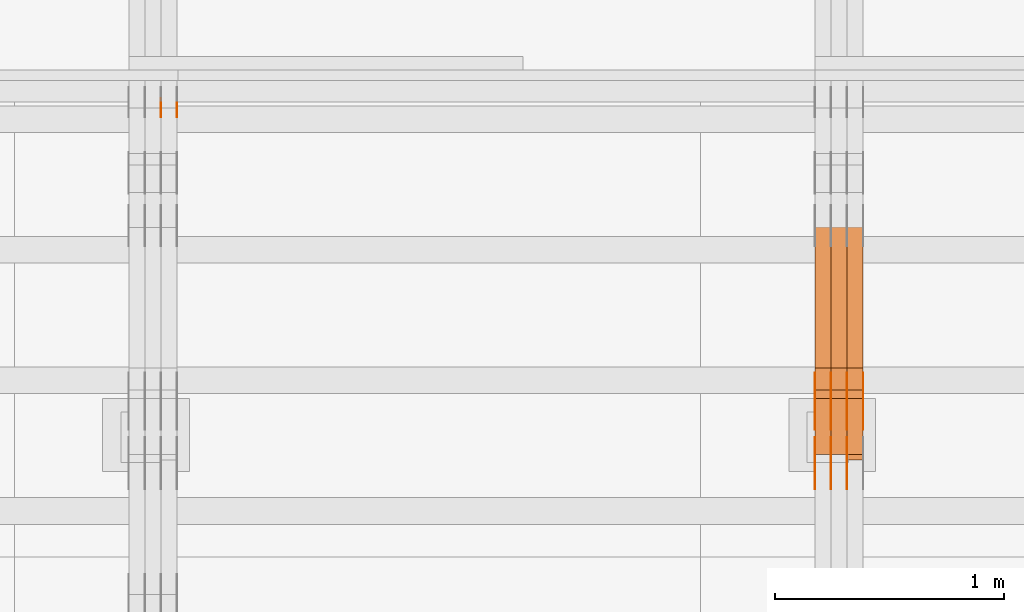
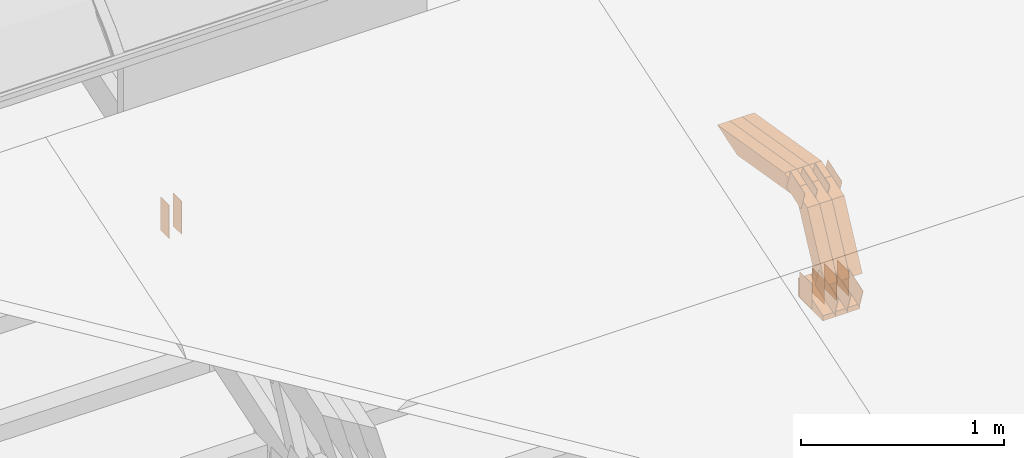
# One storey, part 155 of 385: 29 proxies.
"""IFC2X3 building model written with IfcOpenShell, lengths in millimetres."""

from ifc_helpers import new_model, entity, si_unit, converted_unit, derived_unit, direction, frame, frame_2d, origin, place, context, subcontext, project, spatial, polyline, rectangle, outline, extrude, source, transform, mapped, material, type_object, type_shapes, element, save


model = new_model("IFC2X3")

# Units and contexts
model_context = context("Model", 3, precision=0.01, world=origin(), true_north=direction((6.12303176911189e-17, 1.0)))
body_context = subcontext(model_context, "Body", "Model", "MODEL_VIEW")
ifc_project = project(units=[si_unit("LENGTHUNIT", "METRE", prefix="MILLI"), si_unit("AREAUNIT", "SQUARE_METRE"), si_unit("VOLUMEUNIT", "CUBIC_METRE"), converted_unit("PLANEANGLEUNIT", "DEGREE", entity("IfcRatioMeasure", 0.0174532925199433), si_unit("PLANEANGLEUNIT", "RADIAN"), dimensions=[0, 0, 0, 0, 0, 0, 0]), si_unit("MASSUNIT", "GRAM", prefix="KILO"), derived_unit("MASSDENSITYUNIT", [(si_unit("MASSUNIT", "GRAM", prefix="KILO"), 1), (si_unit("LENGTHUNIT", "METRE"), -3)]), si_unit("TIMEUNIT", "SECOND"), si_unit("FREQUENCYUNIT", "HERTZ"), si_unit("THERMODYNAMICTEMPERATUREUNIT", "DEGREE_CELSIUS"), derived_unit("THERMALTRANSMITTANCEUNIT", [(si_unit("MASSUNIT", "GRAM", prefix="KILO"), 1), (si_unit("THERMODYNAMICTEMPERATUREUNIT", "KELVIN"), -1), (si_unit("TIMEUNIT", "SECOND"), -3)]), derived_unit("VOLUMETRICFLOWRATEUNIT", [(si_unit("LENGTHUNIT", "METRE"), 3), (si_unit("TIMEUNIT", "SECOND"), -1)]), si_unit("ELECTRICCURRENTUNIT", "AMPERE"), si_unit("ELECTRICVOLTAGEUNIT", "VOLT"), si_unit("POWERUNIT", "WATT"), si_unit("FORCEUNIT", "NEWTON", prefix="KILO"), si_unit("ILLUMINANCEUNIT", "LUX"), si_unit("LUMINOUSFLUXUNIT", "LUMEN"), si_unit("LUMINOUSINTENSITYUNIT", "CANDELA"), derived_unit("USERDEFINED", [(si_unit("MASSUNIT", "GRAM", prefix="KILO"), -1), (si_unit("LENGTHUNIT", "METRE"), -2), (si_unit("TIMEUNIT", "SECOND"), 3), (si_unit("LUMINOUSFLUXUNIT", "LUMEN"), 1)]), derived_unit("LINEARVELOCITYUNIT", [(si_unit("LENGTHUNIT", "METRE"), 1), (si_unit("TIMEUNIT", "SECOND"), -1)]), si_unit("PRESSUREUNIT", "PASCAL"), derived_unit("USERDEFINED", [(si_unit("LENGTHUNIT", "METRE"), -2), (si_unit("MASSUNIT", "GRAM", prefix="KILO"), 1), (si_unit("TIMEUNIT", "SECOND"), -2)])], contexts=[model_context])

# Site, building, storey
site_placement = place(None, origin())
site = spatial("IfcSite", under=ifc_project, at=site_placement, CompositionType="ELEMENT")
building_placement = place(site_placement, origin())
building = spatial("IfcBuilding", under=site, at=building_placement, CompositionType="ELEMENT")
storey_placement = place(building_placement, origin())
storey = spatial("IfcBuildingStorey", under=building, at=storey_placement, Name="Default", CompositionType="ELEMENT", Elevation=0.0)

# Proxies
ifc_material_1 = material(Name="IfcSurfaceStyle #344759")
building_element_proxy_type_1 = type_object("IfcBuildingElementProxyType", PredefinedType="NOTDEFINED", material=ifc_material_1)
shared_shape_1 = source(origin(), body_context, "Body", "SweptSolid", [
    extrude(outline(polyline([(-99.9997874178038, -60.0000528641967), (99.9998102700997, -60.0000528641967), (99.9998251396068, 60.0000528641967), (-99.9998479919027, 60.0000528641967), (-99.9997874178038, -60.0000528641967)])), frame((99.9999918898597, 60.0000528641967, 0.0), z_axis=(0.0, 0.0, 1.0), x_axis=(-1.0, 0.0, 0.0)), (0.0, 0.0, 1.0), 1.3),
])
type_shapes(building_element_proxy_type_1, [shared_shape_1])
proxy_1_placement = place(building_placement, frame((27315.0, 11991.9568177725, 3072.52282247925), z_axis=(-1.0, 0.0, 0.0), x_axis=(0.0, 0.951056516295124, 0.309016994375039)))
element("IfcBuildingElementProxy", 1, at=proxy_1_placement, inside=storey, type_object=building_element_proxy_type_1, material=ifc_material_1, context=body_context, shape_type="MappedRepresentation", body=[
    mapped(shared_shape_1, transform((0.0, 0.0, 0.0), scale=1.0)),
])
ifc_material_2 = material(Name="IfcSurfaceStyle #344702")
building_element_proxy_type_2 = type_object("IfcBuildingElementProxyType", PredefinedType="NOTDEFINED", material=ifc_material_2)
shared_shape_2 = source(origin(), body_context, "Body", "SweptSolid", [
    extrude(outline(polyline([(-99.9997874178038, -60.0000528641967), (99.9998102700997, -60.0000528641967), (99.9998251396068, 60.0000528641967), (-99.9998479919027, 60.0000528641967), (-99.9997874178038, -60.0000528641967)])), frame((99.9999918898597, 60.0000528641967, 0.0), z_axis=(0.0, 0.0, 1.0), x_axis=(-1.0, 0.0, 0.0)), (0.0, 0.0, 1.0), 1.3),
])
type_shapes(building_element_proxy_type_2, [shared_shape_2])
proxy_2_placement = place(building_placement, frame((27316.3, 11991.9568177725, 3072.52282247925), z_axis=(-1.0, 0.0, 0.0), x_axis=(0.0, 0.951056516295124, 0.309016994375039)))
element("IfcBuildingElementProxy", 2, at=proxy_2_placement, inside=storey, type_object=building_element_proxy_type_2, material=ifc_material_2, context=body_context, shape_type="MappedRepresentation", body=[
    mapped(shared_shape_2, transform((0.0, 0.0, 0.0), scale=1.0)),
])
ifc_material_3 = material(Name="IfcSurfaceStyle #344645")
building_element_proxy_type_3 = type_object("IfcBuildingElementProxyType", PredefinedType="NOTDEFINED", material=ifc_material_3)
shared_shape_3 = source(origin(), body_context, "Body", "SweptSolid", [
    extrude(outline(polyline([(-99.9997874178038, -60.0000528641967), (99.9998102700997, -60.0000528641967), (99.9998251396068, 60.0000528641967), (-99.9998479919027, 60.0000528641967), (-99.9997874178038, -60.0000528641967)])), frame((99.9999918898597, 60.0000528641967, 0.0), z_axis=(0.0, 0.0, 1.0), x_axis=(-1.0, 0.0, 0.0)), (0.0, 0.0, 1.0), 1.29999999999998),
])
type_shapes(building_element_proxy_type_3, [shared_shape_3])
proxy_3_placement = place(building_placement, frame((27245.0, 11991.9568177725, 3072.52282247925), z_axis=(-1.0, 0.0, 0.0), x_axis=(0.0, 0.951056516295124, 0.309016994375039)))
element("IfcBuildingElementProxy", 3, at=proxy_3_placement, inside=storey, type_object=building_element_proxy_type_3, material=ifc_material_3, context=body_context, shape_type="MappedRepresentation", body=[
    mapped(shared_shape_3, transform((0.0, 0.0, 0.0), scale=1.0)),
])
ifc_material_4 = material(Name="IfcSurfaceStyle #344588")
building_element_proxy_type_4 = type_object("IfcBuildingElementProxyType", PredefinedType="NOTDEFINED", material=ifc_material_4)
shared_shape_4 = source(origin(), body_context, "Body", "SweptSolid", [
    extrude(outline(polyline([(-99.9997874178038, -60.0000528641967), (99.9998102700997, -60.0000528641967), (99.9998251396068, 60.0000528641967), (-99.9998479919027, 60.0000528641967), (-99.9997874178038, -60.0000528641967)])), frame((99.9999918898597, 60.0000528641967, 0.0), z_axis=(0.0, 0.0, 1.0), x_axis=(-1.0, 0.0, 0.0)), (0.0, 0.0, 1.0), 1.29999999999998),
])
type_shapes(building_element_proxy_type_4, [shared_shape_4])
proxy_4_placement = place(building_placement, frame((27246.3, 11991.9568177725, 3072.52282247925), z_axis=(-1.0, 0.0, 0.0), x_axis=(0.0, 0.951056516295124, 0.309016994375039)))
element("IfcBuildingElementProxy", 4, at=proxy_4_placement, inside=storey, type_object=building_element_proxy_type_4, material=ifc_material_4, context=body_context, shape_type="MappedRepresentation", body=[
    mapped(shared_shape_4, transform((0.0, 0.0, 0.0), scale=1.0)),
])
ifc_material_5 = material(Name="IfcSurfaceStyle #344531")
building_element_proxy_type_5 = type_object("IfcBuildingElementProxyType", PredefinedType="NOTDEFINED", material=ifc_material_5)
shared_shape_5 = source(origin(), body_context, "Body", "SweptSolid", [
    extrude(outline(polyline([(-99.9997874178038, -60.0000528641967), (99.9998102700997, -60.0000528641967), (99.9998251396068, 60.0000528641967), (-99.9998479919027, 60.0000528641967), (-99.9997874178038, -60.0000528641967)])), frame((99.9999918898597, 60.0000528641967, 0.0), z_axis=(0.0, 0.0, 1.0), x_axis=(-1.0, 0.0, 0.0)), (0.0, 0.0, 1.0), 1.29999999999999),
])
type_shapes(building_element_proxy_type_5, [shared_shape_5])
proxy_5_placement = place(building_placement, frame((27175.0, 11991.9568177725, 3072.52282247925), z_axis=(-1.0, 0.0, 0.0), x_axis=(0.0, 0.951056516295124, 0.309016994375039)))
element("IfcBuildingElementProxy", 5, at=proxy_5_placement, inside=storey, type_object=building_element_proxy_type_5, material=ifc_material_5, context=body_context, shape_type="MappedRepresentation", body=[
    mapped(shared_shape_5, transform((0.0, 0.0, 0.0), scale=1.0)),
])
ifc_material_6 = material(Name="IfcSurfaceStyle #344474")
building_element_proxy_type_6 = type_object("IfcBuildingElementProxyType", PredefinedType="NOTDEFINED", material=ifc_material_6)
shared_shape_6 = source(origin(), body_context, "Body", "SweptSolid", [
    extrude(rectangle(XDim=150.0, YDim=119.999999999985, at=frame_2d((-7.105427357601e-15, 0.0), x_axis=(1.0, 0.0))), frame((75.0, 60.0, 0.0), z_axis=(0.0, 0.0, 1.0), x_axis=(-1.0, 0.0, 0.0)), (0.0, 0.0, 1.0), 1.3),
])
type_shapes(building_element_proxy_type_6, [shared_shape_6])
proxy_6_placement = place(building_placement, frame((27386.3, 12372.95703125, 3007.04687500001), z_axis=(-1.0, 0.0, 0.0), x_axis=(0.0, 0.0, -1.0)))
element("IfcBuildingElementProxy", 6, at=proxy_6_placement, inside=storey, type_object=building_element_proxy_type_6, material=ifc_material_6, context=body_context, shape_type="MappedRepresentation", body=[
    mapped(shared_shape_6, transform((0.0, 0.0, 0.0), scale=1.0)),
])
ifc_material_7 = material(Name="IfcSurfaceStyle #344417")
building_element_proxy_type_7 = type_object("IfcBuildingElementProxyType", PredefinedType="NOTDEFINED", material=ifc_material_7)
shared_shape_7 = source(origin(), body_context, "Body", "SweptSolid", [
    extrude(rectangle(XDim=150.0, YDim=119.999999999985, at=frame_2d((-7.105427357601e-15, 0.0), x_axis=(1.0, 0.0))), frame((75.0, 60.0, 0.0), z_axis=(0.0, 0.0, 1.0), x_axis=(-1.0, 0.0, 0.0)), (0.0, 0.0, 1.0), 1.3),
])
type_shapes(building_element_proxy_type_7, [shared_shape_7])
proxy_7_placement = place(building_placement, frame((27315.0, 12372.95703125, 3007.04687500001), z_axis=(-1.0, 0.0, 0.0), x_axis=(0.0, 0.0, -1.0)))
element("IfcBuildingElementProxy", 7, at=proxy_7_placement, inside=storey, type_object=building_element_proxy_type_7, material=ifc_material_7, context=body_context, shape_type="MappedRepresentation", body=[
    mapped(shared_shape_7, transform((0.0, 0.0, 0.0), scale=1.0)),
])
ifc_material_8 = material(Name="IfcSurfaceStyle #344360")
building_element_proxy_type_8 = type_object("IfcBuildingElementProxyType", PredefinedType="NOTDEFINED", material=ifc_material_8)
shared_shape_8 = source(origin(), body_context, "Body", "SweptSolid", [
    extrude(rectangle(XDim=150.0, YDim=119.999999999985, at=frame_2d((-7.105427357601e-15, 0.0), x_axis=(1.0, 0.0))), frame((75.0, 60.0, 0.0), z_axis=(0.0, 0.0, 1.0), x_axis=(-1.0, 0.0, 0.0)), (0.0, 0.0, 1.0), 1.3),
])
type_shapes(building_element_proxy_type_8, [shared_shape_8])
proxy_8_placement = place(building_placement, frame((27316.3, 12372.95703125, 3007.04687500001), z_axis=(-1.0, 0.0, 0.0), x_axis=(0.0, 0.0, -1.0)))
element("IfcBuildingElementProxy", 8, at=proxy_8_placement, inside=storey, type_object=building_element_proxy_type_8, material=ifc_material_8, context=body_context, shape_type="MappedRepresentation", body=[
    mapped(shared_shape_8, transform((0.0, 0.0, 0.0), scale=1.0)),
])
ifc_material_9 = material(Name="IfcSurfaceStyle #344303")
building_element_proxy_type_9 = type_object("IfcBuildingElementProxyType", PredefinedType="NOTDEFINED", material=ifc_material_9)
shared_shape_9 = source(origin(), body_context, "Body", "SweptSolid", [
    extrude(rectangle(XDim=150.0, YDim=119.999999999985, at=frame_2d((-7.105427357601e-15, 0.0), x_axis=(1.0, 0.0))), frame((75.0, 60.0, 0.0), z_axis=(0.0, 0.0, 1.0), x_axis=(-1.0, 0.0, 0.0)), (0.0, 0.0, 1.0), 1.29999999999999),
])
type_shapes(building_element_proxy_type_9, [shared_shape_9])
proxy_9_placement = place(building_placement, frame((27245.0, 12372.95703125, 3007.04687500001), z_axis=(-1.0, 0.0, 0.0), x_axis=(0.0, 0.0, -1.0)))
element("IfcBuildingElementProxy", 9, at=proxy_9_placement, inside=storey, type_object=building_element_proxy_type_9, material=ifc_material_9, context=body_context, shape_type="MappedRepresentation", body=[
    mapped(shared_shape_9, transform((0.0, 0.0, 0.0), scale=1.0)),
])
ifc_material_10 = material(Name="IfcSurfaceStyle #344246")
building_element_proxy_type_10 = type_object("IfcBuildingElementProxyType", PredefinedType="NOTDEFINED", material=ifc_material_10)
shared_shape_10 = source(origin(), body_context, "Body", "SweptSolid", [
    extrude(rectangle(XDim=150.0, YDim=119.999999999985, at=frame_2d((-7.105427357601e-15, 0.0), x_axis=(1.0, 0.0))), frame((75.0, 60.0, 0.0), z_axis=(0.0, 0.0, 1.0), x_axis=(-1.0, 0.0, 0.0)), (0.0, 0.0, 1.0), 1.29999999999999),
])
type_shapes(building_element_proxy_type_10, [shared_shape_10])
proxy_10_placement = place(building_placement, frame((27246.3, 12372.95703125, 3007.04687500001), z_axis=(-1.0, 0.0, 0.0), x_axis=(0.0, 0.0, -1.0)))
element("IfcBuildingElementProxy", 10, at=proxy_10_placement, inside=storey, type_object=building_element_proxy_type_10, material=ifc_material_10, context=body_context, shape_type="MappedRepresentation", body=[
    mapped(shared_shape_10, transform((0.0, 0.0, 0.0), scale=1.0)),
])
ifc_material_11 = material(Name="IfcSurfaceStyle #344189")
building_element_proxy_type_11 = type_object("IfcBuildingElementProxyType", PredefinedType="NOTDEFINED", material=ifc_material_11)
shared_shape_11 = source(origin(), body_context, "Body", "SweptSolid", [
    extrude(rectangle(XDim=150.0, YDim=119.999999999985, at=frame_2d((-7.105427357601e-15, 0.0), x_axis=(1.0, 0.0))), frame((75.0, 60.0, 0.0), z_axis=(0.0, 0.0, 1.0), x_axis=(-1.0, 0.0, 0.0)), (0.0, 0.0, 1.0), 1.29999999999999),
])
type_shapes(building_element_proxy_type_11, [shared_shape_11])
proxy_11_placement = place(building_placement, frame((27175.0, 12372.95703125, 3007.04687500001), z_axis=(-1.0, 0.0, 0.0), x_axis=(0.0, 0.0, -1.0)))
element("IfcBuildingElementProxy", 11, at=proxy_11_placement, inside=storey, type_object=building_element_proxy_type_11, material=ifc_material_11, context=body_context, shape_type="MappedRepresentation", body=[
    mapped(shared_shape_11, transform((0.0, 0.0, 0.0), scale=1.0)),
])
ifc_material_12 = material(Name="IfcSurfaceStyle #337292")
building_element_proxy_type_12 = type_object("IfcBuildingElementProxyType", PredefinedType="NOTDEFINED", material=ifc_material_12)
shared_shape_12 = source(origin(), body_context, "Body", "SweptSolid", [
    extrude(outline(polyline([(-74.9998754286244, -60.0000016373506), (74.9998605591063, -60.0000016373506), (74.9998754286244, 60.0000016373506), (-74.9998605591063, 60.0000016373506), (-74.9998754286244, -60.0000016373506)])), frame((74.9998754286244, 60.0000016373506, 0.0), z_axis=(0.0, 0.0, 1.0), x_axis=(-1.0, 0.0, 0.0)), (0.0, 0.0, 1.0), 1.3),
])
type_shapes(building_element_proxy_type_12, [shared_shape_12])
proxy_12_placement = place(building_placement, frame((27386.3, 12321.1620861463, 3506.17707344366), z_axis=(-1.0, 0.0, 0.0), x_axis=(0.0, 0.951056516295154, 0.309016994374948)))
element("IfcBuildingElementProxy", 12, at=proxy_12_placement, inside=storey, type_object=building_element_proxy_type_12, material=ifc_material_12, context=body_context, shape_type="MappedRepresentation", body=[
    mapped(shared_shape_12, transform((0.0, 0.0, 0.0), scale=1.0)),
])
ifc_material_13 = material(Name="IfcSurfaceStyle #337235")
building_element_proxy_type_13 = type_object("IfcBuildingElementProxyType", PredefinedType="NOTDEFINED", material=ifc_material_13)
shared_shape_13 = source(origin(), body_context, "Body", "SweptSolid", [
    extrude(outline(polyline([(-74.9998754286244, -60.0000016373506), (74.9998605591063, -60.0000016373506), (74.9998754286244, 60.0000016373506), (-74.9998605591063, 60.0000016373506), (-74.9998754286244, -60.0000016373506)])), frame((74.9998754286244, 60.0000016373506, 0.0), z_axis=(0.0, 0.0, 1.0), x_axis=(-1.0, 0.0, 0.0)), (0.0, 0.0, 1.0), 1.3),
])
type_shapes(building_element_proxy_type_13, [shared_shape_13])
proxy_13_placement = place(building_placement, frame((27315.0, 12321.1620861463, 3506.17707344366), z_axis=(-1.0, 0.0, 0.0), x_axis=(0.0, 0.951056516295154, 0.309016994374948)))
element("IfcBuildingElementProxy", 13, at=proxy_13_placement, inside=storey, type_object=building_element_proxy_type_13, material=ifc_material_13, context=body_context, shape_type="MappedRepresentation", body=[
    mapped(shared_shape_13, transform((0.0, 0.0, 0.0), scale=1.0)),
])
ifc_material_14 = material(Name="IfcSurfaceStyle #337178")
building_element_proxy_type_14 = type_object("IfcBuildingElementProxyType", PredefinedType="NOTDEFINED", material=ifc_material_14)
shared_shape_14 = source(origin(), body_context, "Body", "SweptSolid", [
    extrude(outline(polyline([(-74.9998754286244, -60.0000016373506), (74.9998605591063, -60.0000016373506), (74.9998754286244, 60.0000016373506), (-74.9998605591063, 60.0000016373506), (-74.9998754286244, -60.0000016373506)])), frame((74.9998754286244, 60.0000016373506, 0.0), z_axis=(0.0, 0.0, 1.0), x_axis=(-1.0, 0.0, 0.0)), (0.0, 0.0, 1.0), 1.3),
])
type_shapes(building_element_proxy_type_14, [shared_shape_14])
proxy_14_placement = place(building_placement, frame((27316.3, 12321.1620861463, 3506.17707344366), z_axis=(-1.0, 0.0, 0.0), x_axis=(0.0, 0.951056516295154, 0.309016994374948)))
element("IfcBuildingElementProxy", 14, at=proxy_14_placement, inside=storey, type_object=building_element_proxy_type_14, material=ifc_material_14, context=body_context, shape_type="MappedRepresentation", body=[
    mapped(shared_shape_14, transform((0.0, 0.0, 0.0), scale=1.0)),
])
ifc_material_15 = material(Name="IfcSurfaceStyle #337121")
building_element_proxy_type_15 = type_object("IfcBuildingElementProxyType", PredefinedType="NOTDEFINED", material=ifc_material_15)
shared_shape_15 = source(origin(), body_context, "Body", "SweptSolid", [
    extrude(outline(polyline([(-74.9998754286244, -60.0000016373506), (74.9998605591063, -60.0000016373506), (74.9998754286244, 60.0000016373506), (-74.9998605591063, 60.0000016373506), (-74.9998754286244, -60.0000016373506)])), frame((74.9998754286244, 60.0000016373506, 0.0), z_axis=(0.0, 0.0, 1.0), x_axis=(-1.0, 0.0, 0.0)), (0.0, 0.0, 1.0), 1.29999999999999),
])
type_shapes(building_element_proxy_type_15, [shared_shape_15])
proxy_15_placement = place(building_placement, frame((27245.0, 12321.1620861463, 3506.17707344366), z_axis=(-1.0, 0.0, 0.0), x_axis=(0.0, 0.951056516295154, 0.309016994374948)))
element("IfcBuildingElementProxy", 15, at=proxy_15_placement, inside=storey, type_object=building_element_proxy_type_15, material=ifc_material_15, context=body_context, shape_type="MappedRepresentation", body=[
    mapped(shared_shape_15, transform((0.0, 0.0, 0.0), scale=1.0)),
])
ifc_material_16 = material(Name="IfcSurfaceStyle #337064")
building_element_proxy_type_16 = type_object("IfcBuildingElementProxyType", PredefinedType="NOTDEFINED", material=ifc_material_16)
shared_shape_16 = source(origin(), body_context, "Body", "SweptSolid", [
    extrude(outline(polyline([(-74.9998754286244, -60.0000016373506), (74.9998605591063, -60.0000016373506), (74.9998754286244, 60.0000016373506), (-74.9998605591063, 60.0000016373506), (-74.9998754286244, -60.0000016373506)])), frame((74.9998754286244, 60.0000016373506, 0.0), z_axis=(0.0, 0.0, 1.0), x_axis=(-1.0, 0.0, 0.0)), (0.0, 0.0, 1.0), 1.29999999999999),
])
type_shapes(building_element_proxy_type_16, [shared_shape_16])
proxy_16_placement = place(building_placement, frame((27246.3, 12321.1620861463, 3506.17707344366), z_axis=(-1.0, 0.0, 0.0), x_axis=(0.0, 0.951056516295154, 0.309016994374948)))
element("IfcBuildingElementProxy", 16, at=proxy_16_placement, inside=storey, type_object=building_element_proxy_type_16, material=ifc_material_16, context=body_context, shape_type="MappedRepresentation", body=[
    mapped(shared_shape_16, transform((0.0, 0.0, 0.0), scale=1.0)),
])
ifc_material_17 = material(Name="IfcSurfaceStyle #337007")
building_element_proxy_type_17 = type_object("IfcBuildingElementProxyType", PredefinedType="NOTDEFINED", material=ifc_material_17)
shared_shape_17 = source(origin(), body_context, "Body", "SweptSolid", [
    extrude(outline(polyline([(-74.9998754286244, -60.0000016373506), (74.9998605591063, -60.0000016373506), (74.9998754286244, 60.0000016373506), (-74.9998605591063, 60.0000016373506), (-74.9998754286244, -60.0000016373506)])), frame((74.9998754286244, 60.0000016373506, 0.0), z_axis=(0.0, 0.0, 1.0), x_axis=(-1.0, 0.0, 0.0)), (0.0, 0.0, 1.0), 1.29999999999999),
])
type_shapes(building_element_proxy_type_17, [shared_shape_17])
proxy_17_placement = place(building_placement, frame((27175.0, 12321.1620861463, 3506.17707344366), z_axis=(-1.0, 0.0, 0.0), x_axis=(0.0, 0.951056516295154, 0.309016994374948)))
element("IfcBuildingElementProxy", 17, at=proxy_17_placement, inside=storey, type_object=building_element_proxy_type_17, material=ifc_material_17, context=body_context, shape_type="MappedRepresentation", body=[
    mapped(shared_shape_17, transform((0.0, 0.0, 0.0), scale=1.0)),
])
ifc_material_18 = material(Name="IfcSurfaceStyle #328832")
building_element_proxy_type_18 = type_object("IfcBuildingElementProxyType", Name="T1-E1 328830", PredefinedType="NOTDEFINED", material=ifc_material_18)
shared_shape_18 = source(origin(), body_context, "Body", "SweptSolid", [
    extrude(outline(polyline([(-75.1378173828004, -122.500000000005), (35.3350830078246, -122.500000000005), (35.3350830078004, 122.500000000005), (4.46765136717545, 122.500000000005), (-75.1378173828004, -122.500000000005)])), frame((35.3350830078246, 122.500000104877, 0.0), z_axis=(0.0, 0.0, 1.0), x_axis=(-1.0, 0.0, 0.0)), (0.0, 0.0, 1.0), 70.0),
])
type_shapes(building_element_proxy_type_18, [shared_shape_18])
proxy_18_placement = place(building_placement, frame((27385.0, 12145.0, 2849.54565429685), z_axis=(-1.0, 0.0, 0.0), x_axis=(0.0, 0.0, 1.0)))
element("IfcBuildingElementProxy", 18, at=proxy_18_placement, inside=storey, type_object=building_element_proxy_type_18, material=ifc_material_18, Name="T1-E1", context=body_context, shape_type="MappedRepresentation", body=[
    mapped(shared_shape_18, transform((0.0, 0.0, 0.0), scale=1.0)),
])
ifc_material_19 = material(Name="IfcSurfaceStyle #328775")
building_element_proxy_type_19 = type_object("IfcBuildingElementProxyType", Name="T1-E1 328773", PredefinedType="NOTDEFINED", material=ifc_material_19)
shared_shape_19 = source(origin(), body_context, "Body", "SweptSolid", [
    extrude(outline(polyline([(-75.1378173828004, -122.500000000005), (35.3350830078246, -122.500000000005), (35.3350830078004, 122.500000000005), (4.46765136717545, 122.500000000005), (-75.1378173828004, -122.500000000005)])), frame((35.3350830078246, 122.500000104877, 0.0), z_axis=(0.0, 0.0, 1.0), x_axis=(-1.0, 0.0, 0.0)), (0.0, 0.0, 1.0), 70.0),
])
type_shapes(building_element_proxy_type_19, [shared_shape_19])
proxy_19_placement = place(building_placement, frame((27315.0, 12145.0, 2849.54565429685), z_axis=(-1.0, 0.0, 0.0), x_axis=(0.0, 0.0, 1.0)))
element("IfcBuildingElementProxy", 19, at=proxy_19_placement, inside=storey, type_object=building_element_proxy_type_19, material=ifc_material_19, Name="T1-E1", context=body_context, shape_type="MappedRepresentation", body=[
    mapped(shared_shape_19, transform((0.0, 0.0, 0.0), scale=1.0)),
])
ifc_material_20 = material(Name="IfcSurfaceStyle #328718")
building_element_proxy_type_20 = type_object("IfcBuildingElementProxyType", Name="T1-E1 328716", PredefinedType="NOTDEFINED", material=ifc_material_20)
shared_shape_20 = source(origin(), body_context, "Body", "SweptSolid", [
    extrude(outline(polyline([(-75.1378173828004, -122.500000000005), (35.3350830078246, -122.500000000005), (35.3350830078004, 122.500000000005), (4.46765136717545, 122.500000000005), (-75.1378173828004, -122.500000000005)])), frame((35.3350830078246, 122.500000104877, 0.0), z_axis=(0.0, 0.0, 1.0), x_axis=(-1.0, 0.0, 0.0)), (0.0, 0.0, 1.0), 70.0),
])
type_shapes(building_element_proxy_type_20, [shared_shape_20])
proxy_20_placement = place(building_placement, frame((27245.0, 12145.0, 2849.54565429685), z_axis=(-1.0, 0.0, 0.0), x_axis=(0.0, 0.0, 1.0)))
element("IfcBuildingElementProxy", 20, at=proxy_20_placement, inside=storey, type_object=building_element_proxy_type_20, material=ifc_material_20, Name="T1-E1", context=body_context, shape_type="MappedRepresentation", body=[
    mapped(shared_shape_20, transform((0.0, 0.0, 0.0), scale=1.0)),
])
ifc_material_21 = material(Name="IfcSurfaceStyle #327104")
building_element_proxy_type_21 = type_object("IfcBuildingElementProxyType", Name="T1-W7 327102", PredefinedType="NOTDEFINED", material=ifc_material_21)
shared_shape_21 = source(origin(), body_context, "Body", "SweptSolid", [
    extrude(outline(polyline([(-296.174043820986, -47.5000676566704), (297.841254477443, -47.5000676566704), (283.518570346415, -7.10254316533821e-06), (192.674144473719, 47.500071207942), (-477.859925476591, 47.500071207942), (-296.174043820986, -47.5000676566704)])), frame((297.841254477443, 47.5000816097442, 0.0), z_axis=(0.0, 0.0, 1.0), x_axis=(-1.0, 0.0, 0.0)), (0.0, 0.0, 1.0), 70.0),
])
type_shapes(building_element_proxy_type_21, [shared_shape_21])
proxy_21_placement = place(building_placement, frame((27385.0, 12419.2991208897, 3526.2136755972), z_axis=(-1.0, 0.0, 0.0), x_axis=(0.0, 0.985983815111804, -0.166840991178939)))
element("IfcBuildingElementProxy", 21, at=proxy_21_placement, inside=storey, type_object=building_element_proxy_type_21, material=ifc_material_21, Name="T1-W7", context=body_context, shape_type="MappedRepresentation", body=[
    mapped(shared_shape_21, transform((0.0, 0.0, 0.0), scale=1.0)),
])
ifc_material_22 = material(Name="IfcSurfaceStyle #327038")
building_element_proxy_type_22 = type_object("IfcBuildingElementProxyType", Name="T1-W7 327036", PredefinedType="NOTDEFINED", material=ifc_material_22)
shared_shape_22 = source(origin(), body_context, "Body", "SweptSolid", [
    extrude(outline(polyline([(-296.174043820986, -47.5000676566704), (297.841254477443, -47.5000676566704), (283.518570346415, -7.10254316533821e-06), (192.674144473719, 47.500071207942), (-477.859925476591, 47.500071207942), (-296.174043820986, -47.5000676566704)])), frame((297.841254477443, 47.5000816097442, 0.0), z_axis=(0.0, 0.0, 1.0), x_axis=(-1.0, 0.0, 0.0)), (0.0, 0.0, 1.0), 70.0),
])
type_shapes(building_element_proxy_type_22, [shared_shape_22])
proxy_22_placement = place(building_placement, frame((27315.0, 12419.2991208897, 3526.2136755972), z_axis=(-1.0, 0.0, 0.0), x_axis=(0.0, 0.985983815111804, -0.166840991178939)))
element("IfcBuildingElementProxy", 22, at=proxy_22_placement, inside=storey, type_object=building_element_proxy_type_22, material=ifc_material_22, Name="T1-W7", context=body_context, shape_type="MappedRepresentation", body=[
    mapped(shared_shape_22, transform((0.0, 0.0, 0.0), scale=1.0)),
])
ifc_material_23 = material(Name="IfcSurfaceStyle #326972")
building_element_proxy_type_23 = type_object("IfcBuildingElementProxyType", Name="T1-W7 326970", PredefinedType="NOTDEFINED", material=ifc_material_23)
shared_shape_23 = source(origin(), body_context, "Body", "SweptSolid", [
    extrude(outline(polyline([(-296.174043820986, -47.5000676566704), (297.841254477443, -47.5000676566704), (283.518570346415, -7.10254316533821e-06), (192.674144473719, 47.500071207942), (-477.859925476591, 47.500071207942), (-296.174043820986, -47.5000676566704)])), frame((297.841254477443, 47.5000816097442, 0.0), z_axis=(0.0, 0.0, 1.0), x_axis=(-1.0, 0.0, 0.0)), (0.0, 0.0, 1.0), 70.0),
])
type_shapes(building_element_proxy_type_23, [shared_shape_23])
proxy_23_placement = place(building_placement, frame((27245.0, 12419.2991208897, 3526.2136755972), z_axis=(-1.0, 0.0, 0.0), x_axis=(0.0, 0.985983815111804, -0.166840991178939)))
element("IfcBuildingElementProxy", 23, at=proxy_23_placement, inside=storey, type_object=building_element_proxy_type_23, material=ifc_material_23, Name="T1-W7", context=body_context, shape_type="MappedRepresentation", body=[
    mapped(shared_shape_23, transform((0.0, 0.0, 0.0), scale=1.0)),
])
ifc_material_24 = material(Name="IfcSurfaceStyle #326708")
building_element_proxy_type_24 = type_object("IfcBuildingElementProxyType", Name="T1-W36 326706", PredefinedType="NOTDEFINED", material=ifc_material_24)
shared_shape_24 = source(origin(), body_context, "Body", "SweptSolid", [
    extrude(outline(polyline([(-300.714670922549, -47.4998881108849), (134.031527004269, -47.499888110885), (180.52054953879, -0.000136170977331764), (193.89900152221, 47.500563476126), (-207.736407142719, 47.4993489166213), (-300.714670922549, -47.4998881108849)])), frame((193.899145164686, 47.5001861375837, 0.0), z_axis=(0.0, 0.0, 1.0), x_axis=(-1.0, 3.02403492980632e-06, 0.0)), (0.0, 0.0, 1.0), 70.0),
])
type_shapes(building_element_proxy_type_24, [shared_shape_24])
proxy_24_placement = place(building_placement, frame((27385.0, 12120.5935627532, 3076.1128858536), z_axis=(-1.0, 0.0, 0.0), x_axis=(0.0, 0.444384650266842, 0.895836080210669)))
element("IfcBuildingElementProxy", 24, at=proxy_24_placement, inside=storey, type_object=building_element_proxy_type_24, material=ifc_material_24, Name="T1-W36", context=body_context, shape_type="MappedRepresentation", body=[
    mapped(shared_shape_24, transform((0.0, 0.0, 0.0), scale=1.0)),
])
ifc_material_25 = material(Name="IfcSurfaceStyle #326642")
building_element_proxy_type_25 = type_object("IfcBuildingElementProxyType", Name="T1-W36 326640", PredefinedType="NOTDEFINED", material=ifc_material_25)
shared_shape_25 = source(origin(), body_context, "Body", "SweptSolid", [
    extrude(outline(polyline([(-300.714670922549, -47.4998881108849), (134.031527004269, -47.499888110885), (180.52054953879, -0.000136170977331764), (193.89900152221, 47.500563476126), (-207.736407142719, 47.4993489166213), (-300.714670922549, -47.4998881108849)])), frame((193.899145164686, 47.5001861375837, 0.0), z_axis=(0.0, 0.0, 1.0), x_axis=(-1.0, 3.02403492980632e-06, 0.0)), (0.0, 0.0, 1.0), 70.0),
])
type_shapes(building_element_proxy_type_25, [shared_shape_25])
proxy_25_placement = place(building_placement, frame((27315.0, 12120.5935627532, 3076.1128858536), z_axis=(-1.0, 0.0, 0.0), x_axis=(0.0, 0.444384650266842, 0.895836080210669)))
element("IfcBuildingElementProxy", 25, at=proxy_25_placement, inside=storey, type_object=building_element_proxy_type_25, material=ifc_material_25, Name="T1-W36", context=body_context, shape_type="MappedRepresentation", body=[
    mapped(shared_shape_25, transform((0.0, 0.0, 0.0), scale=1.0)),
])
ifc_material_26 = material(Name="IfcSurfaceStyle #326576")
building_element_proxy_type_26 = type_object("IfcBuildingElementProxyType", Name="T1-W36 326574", PredefinedType="NOTDEFINED", material=ifc_material_26)
shared_shape_26 = source(origin(), body_context, "Body", "SweptSolid", [
    extrude(outline(polyline([(-300.714670922549, -47.4998881108849), (134.031527004269, -47.499888110885), (180.52054953879, -0.000136170977331764), (193.89900152221, 47.500563476126), (-207.736407142719, 47.4993489166213), (-300.714670922549, -47.4998881108849)])), frame((193.899145164686, 47.5001861375837, 0.0), z_axis=(0.0, 0.0, 1.0), x_axis=(-1.0, 3.02403492980632e-06, 0.0)), (0.0, 0.0, 1.0), 70.0),
])
type_shapes(building_element_proxy_type_26, [shared_shape_26])
proxy_26_placement = place(building_placement, frame((27245.0, 12120.5935627532, 3076.1128858536), z_axis=(-1.0, 0.0, 0.0), x_axis=(0.0, 0.444384650266842, 0.895836080210669)))
element("IfcBuildingElementProxy", 26, at=proxy_26_placement, inside=storey, type_object=building_element_proxy_type_26, material=ifc_material_26, Name="T1-W36", context=body_context, shape_type="MappedRepresentation", body=[
    mapped(shared_shape_26, transform((0.0, 0.0, 0.0), scale=1.0)),
])
ifc_material_27 = material(Name="IfcSurfaceStyle #312436")
building_element_proxy_type_27 = type_object("IfcBuildingElementProxyType", PredefinedType="NOTDEFINED", material=ifc_material_27)
shared_shape_27 = source(origin(), body_context, "Body", "SweptSolid", [
    extrude(rectangle(XDim=200.0, YDim=84.0, at=frame_2d((0.0, -7.105427357601e-15), x_axis=(1.0, 0.0))), frame((100.0, 42.0, 0.0), z_axis=(0.0, 0.0, 1.0), x_axis=(-1.0, 0.0, 0.0)), (0.0, 0.0, 1.0), 1.3),
])
type_shapes(building_element_proxy_type_27, [shared_shape_27])
proxy_27_placement = place(building_placement, frame((24386.3, 13702.0, 3651.4150390625), z_axis=(-1.0, 0.0, 0.0), x_axis=(0.0, 0.0, -1.0)))
element("IfcBuildingElementProxy", 27, at=proxy_27_placement, inside=storey, type_object=building_element_proxy_type_27, material=ifc_material_27, context=body_context, shape_type="MappedRepresentation", body=[
    mapped(shared_shape_27, transform((0.0, 0.0, 0.0), scale=1.0)),
])
ifc_material_28 = material(Name="IfcSurfaceStyle #312379")
building_element_proxy_type_28 = type_object("IfcBuildingElementProxyType", PredefinedType="NOTDEFINED", material=ifc_material_28)
shared_shape_28 = source(origin(), body_context, "Body", "SweptSolid", [
    extrude(rectangle(XDim=200.0, YDim=84.0, at=frame_2d((0.0, -7.105427357601e-15), x_axis=(1.0, 0.0))), frame((100.0, 42.0, 0.0), z_axis=(0.0, 0.0, 1.0), x_axis=(-1.0, 0.0, 0.0)), (0.0, 0.0, 1.0), 1.3),
])
type_shapes(building_element_proxy_type_28, [shared_shape_28])
proxy_28_placement = place(building_placement, frame((24315.0, 13702.0, 3651.4150390625), z_axis=(-1.0, 0.0, 0.0), x_axis=(0.0, 0.0, -1.0)))
element("IfcBuildingElementProxy", 28, at=proxy_28_placement, inside=storey, type_object=building_element_proxy_type_28, material=ifc_material_28, context=body_context, shape_type="MappedRepresentation", body=[
    mapped(shared_shape_28, transform((0.0, 0.0, 0.0), scale=1.0)),
])
ifc_material_29 = material(Name="IfcSurfaceStyle #312322")
building_element_proxy_type_29 = type_object("IfcBuildingElementProxyType", PredefinedType="NOTDEFINED", material=ifc_material_29)
shared_shape_29 = source(origin(), body_context, "Body", "SweptSolid", [
    extrude(rectangle(XDim=200.0, YDim=84.0, at=frame_2d((0.0, -7.105427357601e-15), x_axis=(1.0, 0.0))), frame((100.0, 42.0, 0.0), z_axis=(0.0, 0.0, 1.0), x_axis=(-1.0, 0.0, 0.0)), (0.0, 0.0, 1.0), 1.3),
])
type_shapes(building_element_proxy_type_29, [shared_shape_29])
proxy_29_placement = place(building_placement, frame((24316.3, 13702.0, 3651.4150390625), z_axis=(-1.0, 0.0, 0.0), x_axis=(0.0, 0.0, -1.0)))
element("IfcBuildingElementProxy", 29, at=proxy_29_placement, inside=storey, type_object=building_element_proxy_type_29, material=ifc_material_29, context=body_context, shape_type="MappedRepresentation", body=[
    mapped(shared_shape_29, transform((0.0, 0.0, 0.0), scale=1.0)),
])

save(model, "model.ifc")
